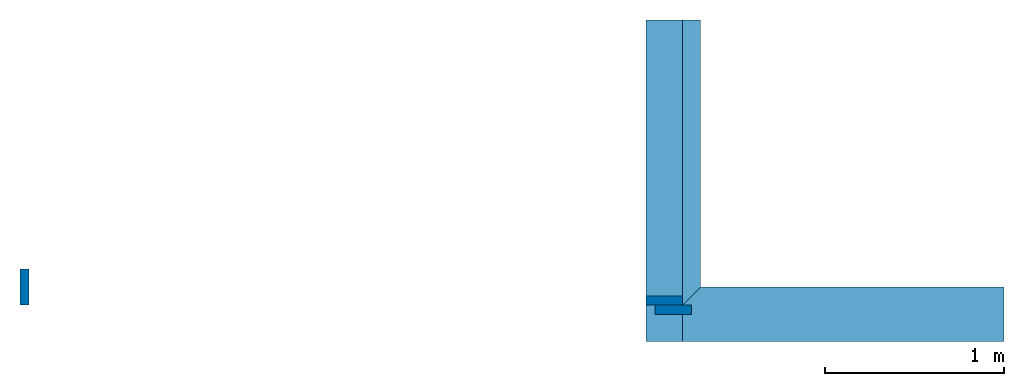
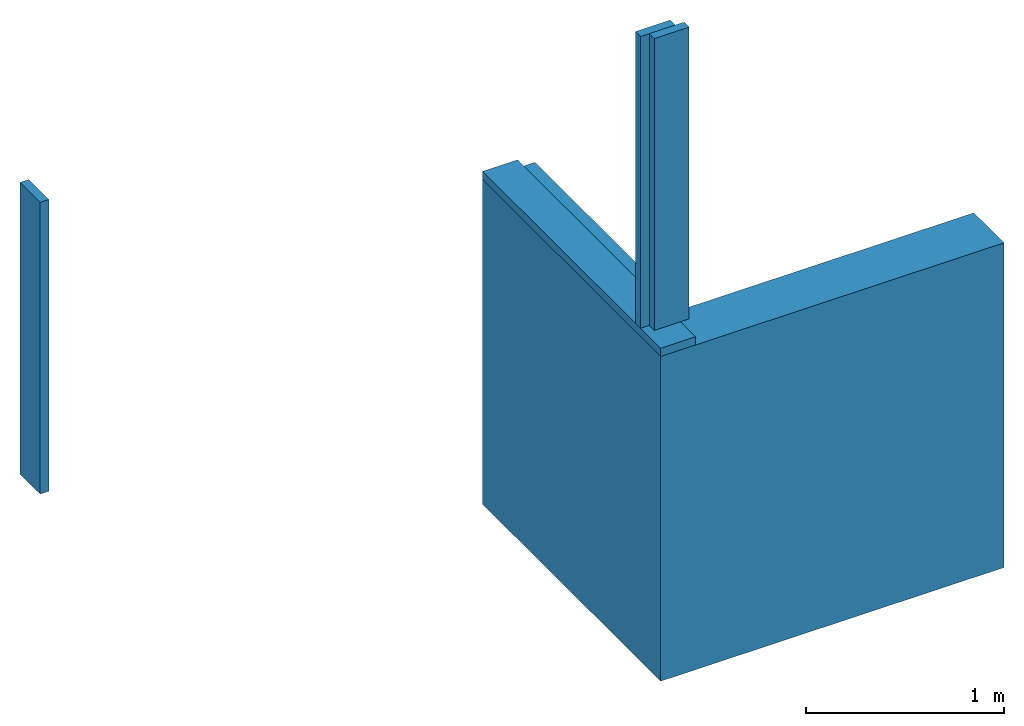
# One storey: 6 walls.
"""IFC4 building model written with IfcOpenShell, lengths in inches."""

from ifc_helpers import new_model, entity, si_unit, converted_unit, frame, frame_2d, origin_with_axes, place, context, subcontext, project, spatial, polygons, material, element, save


model = new_model("IFC4")

# Units and contexts
model_context = context("Model", 3, precision=1e-05, world=origin_with_axes())
plan_context = context("Plan", 2, precision=1e-05, world=frame_2d((0.0, 0.0, 0.0), x_axis=(1.0, 0.0, 0.0)))
body_context = subcontext(model_context, "Body", "Model", "MODEL_VIEW")
ifc_project = project(units=[converted_unit("AREAUNIT", "square inch", entity("IfcReal", 0.0006452), si_unit("AREAUNIT", "SQUARE_METRE"), dimensions=[2, 0, 0, 0, 0, 0, 0]), converted_unit("LENGTHUNIT", "inch", entity("IfcReal", 0.0254), si_unit("LENGTHUNIT", "METRE"), dimensions=[1, 0, 0, 0, 0, 0, 0]), converted_unit("VOLUMEUNIT", "cubic inch", entity("IfcReal", 1.639e-05), si_unit("VOLUMEUNIT", "CUBIC_METRE"), dimensions=[3, 0, 0, 0, 0, 0, 0])], contexts=[model_context, plan_context])

# Site, building, storey
site_placement = place(None, origin_with_axes())
site = spatial("IfcSite", under=ifc_project, at=site_placement)
building_placement = place(site_placement, origin_with_axes())
building = spatial("IfcBuilding", under=site, at=building_placement, Name="Building")
storey_placement = place(building_placement, origin_with_axes())
storey = spatial("IfcBuildingStorey", under=building, at=storey_placement, Name="Storey")

# Walls
ifc_material = material(Name="Concrete")
wall_1_placement = place(storey_placement, frame((0.18779217727541, 0.204054389412948, 0.0), z_axis=(0.0, 0.0, 1.0), x_axis=(1.0, 0.0, 0.0)))
element("IfcWall", 1, at=wall_1_placement, inside=storey, material=ifc_material, PredefinedType="ELEMENTEDWALL", context=body_context, shape_type="Tessellation", body=[
    polygons([(78.7401580810547, 0.0, 0.0), (-1.17331978799484e-06, 0.0, 0.0), (78.7401580810547, 0.0, 78.7401580810547), (-1.17331978799484e-06, 0.0, 78.7401580810547), (78.7401580810547, 12.0000009536743, 0.0), (12.0, 12.0000009536743, 0.0), (78.7401580810547, 12.0000009536743, 78.7401580810547), (12.0, 12.0000009536743, 78.7401580810547)], [[[2, 1, 3, 4]], [[6, 8, 7, 5]], [[2, 4, 8, 6]], [[1, 2, 6, 5]], [[4, 3, 7, 8]], [[3, 1, 5, 7]]]),
])
wall_2_placement = place(storey_placement, frame((12.1877946722226, 0.204054389412948, -1.17331977904312e-06), z_axis=(0.0, 0.0, 1.0), x_axis=(-1.62920684942947e-07, 1.0, 0.0)))
element("IfcWall", 2, at=wall_2_placement, inside=storey, PredefinedType="ELEMENTEDWALL", context=body_context, shape_type="Tessellation", body=[
    polygons([(12.0000028610229, 6.39863571905153e-07, 0.0), (12.0000028610229, 6.39863571905153e-07, 78.7401580810547), (1.17331978799484e-06, 12.0000028610229, 0.0), (1.17331978799484e-06, 12.0000028610229, 78.7401580810547), (70.7401580810547, 1.17331978799484e-06, 78.7401580810547), (70.7401580810547, 1.17331978799484e-06, 0.0), (70.7401580810547, 12.0000028610229, 78.7401580810547), (70.7401580810547, 12.0000028610229, 0.0)], [[[1, 6, 5, 2]], [[3, 4, 7, 8]], [[1, 2, 4, 3]], [[6, 1, 3, 8]], [[2, 5, 7, 4]], [[5, 6, 8, 7]]]),
])
for number, where, z_axis, x_axis in (
    (3, (8.18779325391364, -7.79594492724561, -56.9757514112578), (0.0, 0.0, 1.0), (-4.37113882867379e-08, 1.0, 0.0)),
    (4, (0.18779159061552, 8.20405605271107, 80.7401608294389), (-1.0, 0.0, 1.19248806385031e-08), (1.19248806385031e-08, 0.0, 1.0)),
):
    element("IfcWall", number, at=place(storey_placement, frame(where, z_axis=z_axis, x_axis=x_axis)), inside=storey, PredefinedType="ELEMENTEDWALL", context=body_context, shape_type="Tessellation", body=[
        polygons([(78.7401580810547, 0.0, 135.715911865234), (78.7401580810547, 0.0, 137.715911865234), (78.7401580810547, 8.00000095367432, 135.715911865234), (78.7401580810547, 8.00000095367432, 137.715911865234), (8.0, 0.0, 135.715911865234), (8.0, 8.00000095367432, 135.715911865234), (8.0, 0.0, 137.715911865234), (8.0, 8.00000095367432, 137.715911865234)], [[[6, 3, 1, 5]], [[7, 2, 4, 8]], [[5, 1, 2, 7]], [[1, 3, 4, 2]], [[3, 6, 8, 4]], [[6, 5, 7, 8]]]),
    ])
for number, where, z_axis, x_axis in (
    (5, (0.187791003955631, 8.20405546605118, 80.7401608294389), (4.37113882867379e-08, -1.0, -5.21253117251541e-16), (1.19248806385031e-08, 0.0, 1.0)),
    (6, (2.18779435307961, 6.2040521169272, 80.7401514428807), (4.37113882867379e-08, -1.0, -5.21253117251541e-16), (1.19248806385031e-08, 0.0, 1.0)),
):
    element("IfcWall", number, at=place(storey_placement, frame(where, z_axis=z_axis, x_axis=x_axis)), inside=storey, PredefinedType="ELEMENTEDWALL", context=body_context, shape_type="Tessellation", body=[
        polygons([(70.7401580810547, -8.00000190734863, -2.00000333786011), (70.7401580810547, -8.00000190734863, 0.0), (70.7401580810547, -5.86659893997421e-07, -2.00000333786011), (70.7401580810547, -5.86659893997421e-07, 0.0), (0.0, -8.00000190734863, -2.00000333786011), (0.0, -5.86659893997421e-07, -2.00000333786011), (0.0, -8.00000190734863, 0.0), (0.0, -5.86659893997421e-07, 0.0)], [[[6, 3, 1, 5]], [[7, 2, 4, 8]], [[5, 1, 2, 7]], [[1, 3, 4, 2]], [[3, 6, 8, 4]], [[6, 5, 7, 8]]]),
    ])

save(model, "model.ifc")
